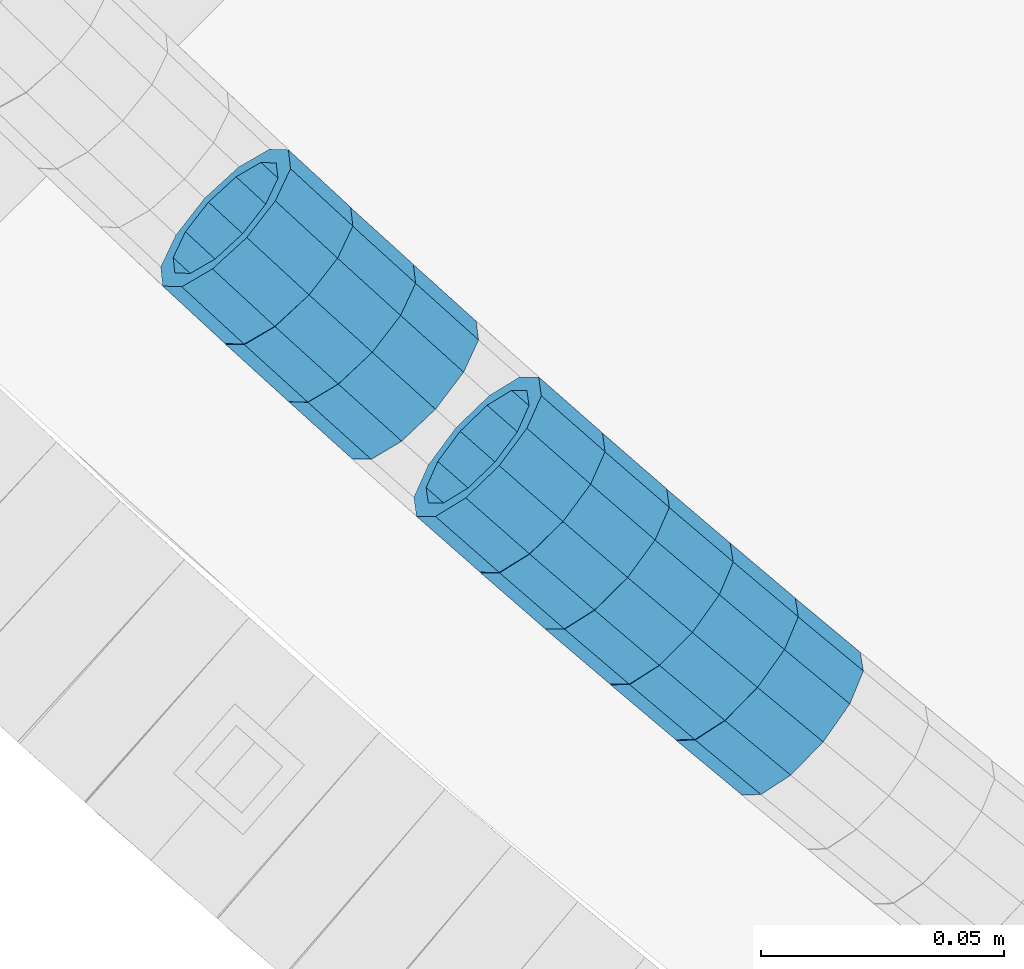
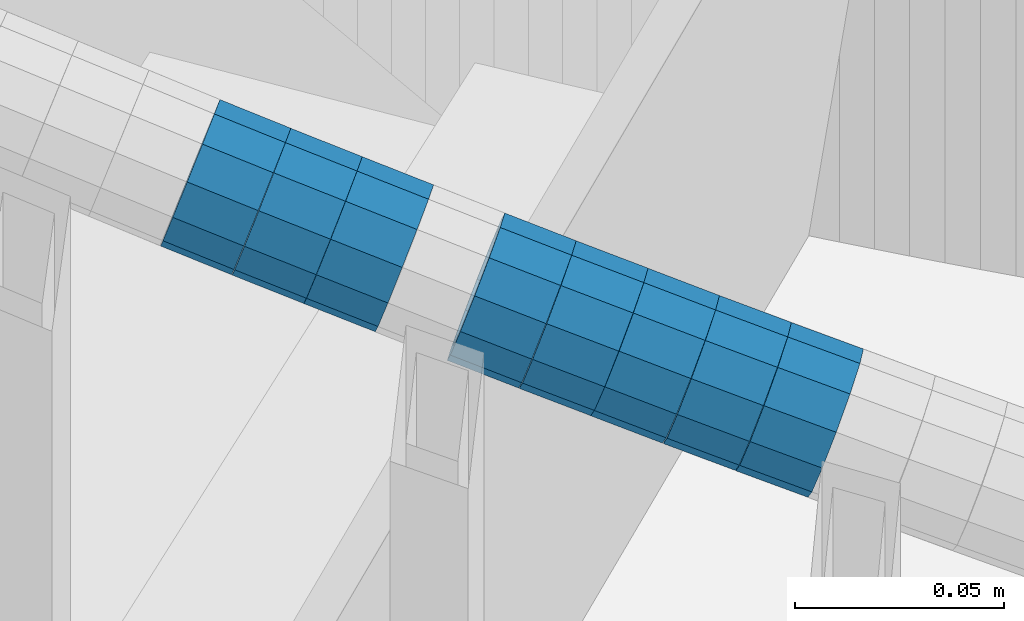
# One storey, part 659 of 975: 8 beams.
"""IFC2X3 building model written with IfcOpenShell, lengths in millimetres."""

from ifc_helpers import new_model, si_unit, frame, origin_with_axes, place, context, subcontext, project, spatial, faceted_brep, material, type_object, element, save


model = new_model("IFC2X3")

# Units and contexts
model_context = context("Model", 3, precision=1e-05, world=origin_with_axes())
body_context = subcontext(model_context, "Body", "Model", "MODEL_VIEW")
ifc_project = project(units=[si_unit("LENGTHUNIT", "METRE", prefix="MILLI"), si_unit("AREAUNIT", "SQUARE_METRE"), si_unit("VOLUMEUNIT", "CUBIC_METRE"), si_unit("MASSUNIT", "GRAM", prefix="KILO"), si_unit("TIMEUNIT", "SECOND"), si_unit("PLANEANGLEUNIT", "RADIAN"), si_unit("SOLIDANGLEUNIT", "STERADIAN"), si_unit("THERMODYNAMICTEMPERATUREUNIT", "DEGREE_CELSIUS"), si_unit("LUMINOUSINTENSITYUNIT", "LUMEN")], contexts=[model_context])

# Site, building, storey
site_placement = place(None, origin_with_axes())
site = spatial("IfcSite", under=ifc_project, at=site_placement, CompositionType="ELEMENT")
building_placement = place(site_placement, origin_with_axes())
building = spatial("IfcBuilding", under=site, at=building_placement, Name="Undefined", CompositionType="ELEMENT")
storey_placement = place(building_placement, origin_with_axes())
storey = spatial("IfcBuildingStorey", under=building, at=storey_placement, Name="Undefined", CompositionType="ELEMENT", Elevation=0.0)

# Beams
ifc_material = material()
beam_type = type_object("IfcBeamType", PredefinedType="NOTDEFINED")
beam_1_placement = place(storey_placement, frame((32885.447140122, 1317.11341799505, 4870.99343661402), z_axis=(0.659722162341103, 0.751509593096442, -6.30179783911445e-11), x_axis=(0.714291660288527, -0.627049931253341, -0.310798661125558)))
element("IfcBeam", 1, at=beam_1_placement, inside=storey, type_object=beam_type, material=ifc_material, Name="WALL", context=body_context, shape_type="Brep", body=[
    faceted_brep([(-2.1246523829177e-07, -15.367000000002, 0.0), (-1.83998054126278e-07, -13.3082123799541, 7.68350000000009), (18.3398473276247, -13.3082123799522, 7.68350000000646), (18.3398473276393, -15.3670000000002, 1.81898940354586e-11), (-1.06232619145885e-07, -7.68349999999919, 13.3082123799559), (18.3398473276029, -7.68349999999373, 13.3082123799395), (-3.63797880709171e-12, 3.63797880709171e-12, 15.3670000000002), (18.3398473275956, 5.45696821063757e-12, 15.3669999999802), (1.06225343188271e-07, 7.68350000000646, 13.3082123799559), (18.3398473275993, 7.683500000001, 13.3082123799359), (1.8399441614747e-07, 13.308212379965, 7.68350000000009), (18.3398473276029, 13.3082123799559, 7.68349999998827), (2.12461600312963e-07, 15.3670000000093, 0.0), (18.3398473276247, 15.3669999999966, 7.27595761418343e-12), (1.8399441614747e-07, 13.308212379965, -7.68350000000009), (18.3398473276466, 13.308212379945, -7.68349999997372), (1.06225343188271e-07, 7.68350000000646, -13.3082123799559), (18.3398473276611, 7.68349999999009, -13.3082123799177), (-3.63797880709171e-12, 3.63797880709171e-12, -15.3670000000002), (18.3398473276684, -9.09494701772928e-12, -15.3669999999547), (-1.06232619145885e-07, -7.68349999999919, -13.3082123799559), (18.3398473276684, -7.68350000000828, -13.3082123799104), (-1.83998054126278e-07, -13.3082123799541, -7.68350000000009), (18.3398473276611, -13.3082123799613, -7.68349999996644), (-2.63386027654633e-07, -19.0500000000029, 0.0), (-2.28097633225843e-07, -16.4977839420972, -9.52499999999964), (18.3398473276648, -16.497783942099, -9.52499999996144), (18.3398473276466, -19.0500000000011, 2.18278728425503e-11), (-1.31691194837913e-07, -9.52500000000146, -16.4977839420935), (18.3398473276793, -9.52500000000873, -16.4977839420426), (-3.63797880709171e-12, 3.63797880709171e-12, -19.0500000000002), (18.3398473276793, -1.09139364212751e-11, -19.0499999999483), (1.31687556859106e-07, 9.52500000000509, -16.4977839420935), (18.339847327672, 9.52499999998872, -16.4977839420462), (2.28097633225843e-07, 16.4977839421044, -9.52499999999964), (18.3398473276466, 16.4977839420844, -9.52499999997235), (2.63382389675826e-07, 19.0500000000138, 0.0), (18.3398473276247, 19.0499999999938, 7.27595761418343e-12), (2.28097633225843e-07, 16.4977839421044, 9.52499999999964), (18.3398473275993, 16.4977839420935, 9.5249999999869), (1.31687556859106e-07, 9.52500000000509, 16.4977839420935), (18.3398473275884, 9.52500000000327, 16.4977839420681), (-3.63797880709171e-12, 3.63797880709171e-12, 19.0500000000002), (18.3398473275884, 7.27595761418343e-12, 19.0499999999738), (-1.31691194837913e-07, -9.52500000000146, 16.4977839420935), (18.3398473276029, -9.52499999999236, 16.4977839420753), (-2.28097633225843e-07, -16.4977839420972, 9.52499999999964), (18.3398473276211, -16.4977839420899, 9.52499999999782)], [[[0, 1, 2, 3]], [[1, 4, 5, 2]], [[4, 6, 7, 5]], [[6, 8, 9, 7]], [[8, 10, 11, 9]], [[10, 12, 13, 11]], [[12, 14, 15, 13]], [[14, 16, 17, 15]], [[16, 18, 19, 17]], [[18, 20, 21, 19]], [[20, 22, 23, 21]], [[22, 0, 3, 23]], [[24, 25, 26, 27]], [[25, 28, 29, 26]], [[28, 30, 31, 29]], [[30, 32, 33, 31]], [[32, 34, 35, 33]], [[34, 36, 37, 35]], [[36, 38, 39, 37]], [[38, 40, 41, 39]], [[40, 42, 43, 41]], [[42, 44, 45, 43]], [[44, 46, 47, 45]], [[46, 24, 27, 47]], [[29, 31, 33, 35, 37, 39, 41, 43, 45, 47, 27, 26], [5, 7, 9, 11, 13, 15, 17, 19, 21, 23, 3, 2]], [[46, 44, 42, 40, 38, 36, 34, 32, 30, 28, 25, 24], [22, 20, 18, 16, 14, 12, 10, 8, 6, 4, 1, 0]]]),
])
beam_2_placement = place(storey_placement, frame((32846.4408582709, 1352.26107727373, 4888.18099728971), z_axis=(0.672105592443994, 0.740455314388051, 2.18336936086416e-10), x_axis=(0.704268340887311, -0.639258954897755, -0.308794579950596)))
element("IfcBeam", 2, at=beam_2_placement, inside=storey, type_object=beam_type, material=ifc_material, Name="WALL", context=body_context, shape_type="Brep", body=[
    faceted_brep([(-2.1246523829177e-07, -15.367000000002, 0.0), (-1.83998054126278e-07, -13.3082123799541, 7.68350000000009), (18.4599566630168, -13.3082123799522, 7.68349999999555), (18.4599566630277, -15.3670000000002, 3.63797880709171e-12), (-1.06232619145885e-07, -7.68349999999919, 13.3082123799559), (18.4599566630131, -7.68349999999373, 13.3082123799468), (-3.63797880709171e-12, 3.63797880709171e-12, 15.3670000000002), (18.4599566630059, 7.27595761418343e-12, 15.3669999999911), (1.06225343188271e-07, 7.68350000000646, 13.3082123799559), (18.4599566630059, 7.68350000000646, 13.3082123799431), (1.8399441614747e-07, 13.308212379965, 7.68350000000009), (18.4599566630131, 13.3082123799595, 7.68349999999555), (2.12461600312963e-07, 15.3670000000093, 0.0), (18.4599566630241, 15.3670000000002, 0.0), (1.8399441614747e-07, 13.308212379965, -7.68350000000009), (18.4599566630313, 13.3082123799522, -7.68349999999191), (1.06225343188271e-07, 7.68350000000646, -13.3082123799559), (18.459956663035, 7.68349999999555, -13.3082123799431), (-3.63797880709171e-12, 3.63797880709171e-12, -15.3670000000002), (18.459956663035, -3.63797880709171e-12, -15.3669999999875), (-1.06232619145885e-07, -7.68349999999919, -13.3082123799559), (18.459956663035, -7.68350000000464, -13.3082123799431), (-1.83998054126278e-07, -13.3082123799541, -7.68350000000009), (18.459956663035, -13.3082123799559, -7.68349999999191), (-2.63386027654633e-07, -19.0500000000029, 0.0), (-2.28097633225843e-07, -16.4977839420972, -9.52499999999964), (18.459956663035, -16.4977839420953, -9.5249999999869), (18.4599566630241, -19.0499999999975, 3.63797880709171e-12), (-1.31691194837913e-07, -9.52500000000146, -16.4977839420935), (18.4599566630386, -9.52500000000327, -16.497783942079), (-3.63797880709171e-12, 3.63797880709171e-12, -19.0500000000002), (18.4599566630422, -5.45696821063757e-12, -19.0499999999811), (1.31687556859106e-07, 9.52500000000509, -16.4977839420935), (18.4599566630386, 9.52499999999418, -16.497783942079), (2.28097633225843e-07, 16.4977839421044, -9.52499999999964), (18.4599566630277, 16.4977839420917, -9.52499999999418), (2.63382389675826e-07, 19.0500000000138, 0.0), (18.4599566630168, 19.0500000000011, -3.63797880709171e-12), (2.28097633225843e-07, 16.4977839421044, 9.52499999999964), (18.4599566630131, 16.4977839420972, 9.52499999999054), (1.31687556859106e-07, 9.52500000000509, 16.4977839420935), (18.4599566630095, 9.52500000000691, 16.497783942079), (-3.63797880709171e-12, 3.63797880709171e-12, 19.0500000000002), (18.4599566630059, 7.27595761418343e-12, 19.0499999999884), (-1.31691194837913e-07, -9.52500000000146, 16.4977839420935), (18.4599566630095, -9.52499999999236, 16.4977839420826), (-2.28097633225843e-07, -16.4977839420972, 9.52499999999964), (18.4599566630168, -16.4977839420881, 9.52499999999418)], [[[0, 1, 2, 3]], [[1, 4, 5, 2]], [[4, 6, 7, 5]], [[6, 8, 9, 7]], [[8, 10, 11, 9]], [[10, 12, 13, 11]], [[12, 14, 15, 13]], [[14, 16, 17, 15]], [[16, 18, 19, 17]], [[18, 20, 21, 19]], [[20, 22, 23, 21]], [[22, 0, 3, 23]], [[24, 25, 26, 27]], [[25, 28, 29, 26]], [[28, 30, 31, 29]], [[30, 32, 33, 31]], [[32, 34, 35, 33]], [[34, 36, 37, 35]], [[36, 38, 39, 37]], [[38, 40, 41, 39]], [[40, 42, 43, 41]], [[42, 44, 45, 43]], [[44, 46, 47, 45]], [[46, 24, 27, 47]], [[29, 31, 33, 35, 37, 39, 41, 43, 45, 47, 27, 26], [5, 7, 9, 11, 13, 15, 17, 19, 21, 23, 3, 2]], [[46, 44, 42, 40, 38, 36, 34, 32, 30, 28, 25, 24], [22, 20, 18, 16, 14, 12, 10, 8, 6, 4, 1, 0]]]),
])
beam_3_placement = place(storey_placement, frame((32898.5526975235, 1305.54987548139, 4865.27848180664), z_axis=(0.65406398915987, 0.756439222994338, 2.04823663807474e-10), x_axis=(0.719570981002803, -0.622185434002454, -0.308387563001237)))
element("IfcBeam", 3, at=beam_3_placement, inside=storey, type_object=beam_type, material=ifc_material, Name="WALL", context=body_context, shape_type="Brep", body=[
    faceted_brep([(-2.1246523829177e-07, -15.367000000002, 0.0), (-1.83998054126278e-07, -13.3082123799541, 7.68350000000009), (18.4753890351749, -13.3082123799613, 7.6835000000101), (18.4753890351676, -15.3670000000056, 0.0), (-1.06232619145885e-07, -7.68349999999919, 13.3082123799559), (18.4753890351822, -7.6835000000101, 13.3082123799686), (-3.63797880709171e-12, 3.63797880709171e-12, 15.3670000000002), (18.4753890351967, -1.2732925824821e-11, 15.3670000000238), (1.06225343188271e-07, 7.68350000000646, 13.3082123799559), (18.475389035204, 7.68349999998463, 13.3082123799832), (1.8399441614747e-07, 13.308212379965, 7.68350000000009), (18.4753890352004, 13.3082123799395, 7.68350000002465), (2.12461600312963e-07, 15.3670000000093, 0.0), (18.4753890351967, 15.3669999999838, 2.5465851649642e-11), (1.8399441614747e-07, 13.308212379965, -7.68350000000009), (18.4753890351894, 13.3082123799413, -7.68349999998463), (1.06225343188271e-07, 7.68350000000646, -13.3082123799559), (18.4753890351749, 7.68349999998827, -13.3082123799468), (-3.63797880709171e-12, 3.63797880709171e-12, -15.3670000000002), (18.4753890351676, -1.09139364212751e-11, -15.3669999999947), (-1.06232619145885e-07, -7.68349999999919, -13.3082123799559), (18.4753890351676, -7.68350000000646, -13.3082123799577), (-1.83998054126278e-07, -13.3082123799541, -7.68350000000009), (18.4753890351567, -13.3082123799613, -7.68350000000282), (-2.63386027654633e-07, -19.0500000000029, 0.0), (-2.28097633225843e-07, -16.4977839420972, -9.52499999999964), (18.4753890351567, -16.4977839420972, -9.52500000000873), (18.4753890351676, -19.0500000000065, 0.0), (-1.31691194837913e-07, -9.52500000000146, -16.4977839420935), (18.475389035164, -9.52500000000873, -16.4977839420972), (-3.63797880709171e-12, 3.63797880709171e-12, -19.0500000000002), (18.475389035164, -9.09494701772928e-12, -19.0499999999993), (1.31687556859106e-07, 9.52500000000509, -16.4977839420935), (18.4753890351822, 9.5249999999869, -16.497783942079), (2.28097633225843e-07, 16.4977839421044, -9.52499999999964), (18.4753890351931, 16.497783942079, -9.52499999997963), (2.63382389675826e-07, 19.0500000000138, 0.0), (18.475389035204, 19.0499999999847, 2.91038304567337e-11), (2.28097633225843e-07, 16.4977839421044, 9.52499999999964), (18.4753890352113, 16.4977839420753, 9.5250000000342), (1.31687556859106e-07, 9.52500000000509, 16.4977839420935), (18.475389035204, 9.52499999998327, 16.4977839421226), (-3.63797880709171e-12, 3.63797880709171e-12, 19.0500000000002), (18.4753890352004, -1.45519152283669e-11, 19.0500000000284), (-1.31691194837913e-07, -9.52500000000146, 16.4977839420935), (18.4753890351858, -9.52500000000873, 16.4977839421081), (-2.28097633225843e-07, -16.4977839420972, 9.52499999999964), (18.4753890351749, -16.4977839421008, 9.52500000000509)], [[[0, 1, 2, 3]], [[1, 4, 5, 2]], [[4, 6, 7, 5]], [[6, 8, 9, 7]], [[8, 10, 11, 9]], [[10, 12, 13, 11]], [[12, 14, 15, 13]], [[14, 16, 17, 15]], [[16, 18, 19, 17]], [[18, 20, 21, 19]], [[20, 22, 23, 21]], [[22, 0, 3, 23]], [[24, 25, 26, 27]], [[25, 28, 29, 26]], [[28, 30, 31, 29]], [[30, 32, 33, 31]], [[32, 34, 35, 33]], [[34, 36, 37, 35]], [[36, 38, 39, 37]], [[38, 40, 41, 39]], [[40, 42, 43, 41]], [[42, 44, 45, 43]], [[44, 46, 47, 45]], [[46, 24, 27, 47]], [[29, 31, 33, 35, 37, 39, 41, 43, 45, 47, 27, 26], [5, 7, 9, 11, 13, 15, 17, 19, 21, 23, 3, 2]], [[46, 44, 42, 40, 38, 36, 34, 32, 30, 28, 25, 24], [22, 20, 18, 16, 14, 12, 10, 8, 6, 4, 1, 0]]]),
])
beam_4_placement = place(storey_placement, frame((32911.7181026695, 1294.0974046981, 4859.62218127708), z_axis=(0.647482078321744, 0.762080676996967, 1.71126885106787e-10), x_axis=(0.723189311042996, -0.6144390380365, -0.315375790018729)))
element("IfcBeam", 4, at=beam_4_placement, inside=storey, type_object=beam_type, material=ifc_material, Name="WALL", context=body_context, shape_type="Brep", body=[
    faceted_brep([(-2.1246523829177e-07, -15.367000000002, 0.0), (-1.83998054126278e-07, -13.3082123799541, 7.68350000000009), (18.3929334256754, -13.3082123799595, 7.68350000001374), (18.39293342569, -15.3670000000111, 3.27418092638254e-11), (-1.06232619145885e-07, -7.68349999999919, 13.3082123799559), (18.3929334256572, -7.68349999999373, 13.3082123799504), (-3.63797880709171e-12, 3.63797880709171e-12, 15.3670000000002), (18.3929334256391, 1.2732925824821e-11, 15.3669999999802), (1.06225343188271e-07, 7.68350000000646, 13.3082123799559), (18.3929334256318, 7.68350000001556, 13.3082123799286), (1.8399441614747e-07, 13.308212379965, 7.68350000000009), (18.3929334256391, 13.3082123799704, 7.68349999997736), (2.12461600312963e-07, 15.3670000000093, 0.0), (18.3929334256536, 15.3670000000111, -1.09139364212751e-11), (1.8399441614747e-07, 13.308212379965, -7.68350000000009), (18.3929334256682, 13.3082123799595, -7.68349999999191), (1.06225343188271e-07, 7.68350000000646, -13.3082123799559), (18.3929334256864, 7.68349999999373, -13.3082123799286), (-3.63797880709171e-12, 3.63797880709171e-12, -15.3670000000002), (18.3929334257045, -1.2732925824821e-11, -15.3669999999584), (-1.06232619145885e-07, -7.68349999999919, -13.3082123799559), (18.3929334257118, -7.68350000001919, -13.3082123799068), (-1.83998054126278e-07, -13.3082123799541, -7.68350000000009), (18.3929334257082, -13.3082123799704, -7.68349999995553), (-2.63386027654633e-07, -19.0500000000029, 0.0), (-2.28097633225843e-07, -16.4977839420972, -9.52499999999964), (18.3929334257155, -16.4977839421135, -9.52499999994689), (18.3929334257009, -19.0500000000156, 3.63797880709171e-11), (-1.31691194837913e-07, -9.52500000000146, -16.4977839420935), (18.3929334257191, -9.52500000002146, -16.4977839420353), (-3.63797880709171e-12, 3.63797880709171e-12, -19.0500000000002), (18.3929334257155, -1.81898940354586e-11, -19.0499999999483), (1.31687556859106e-07, 9.52500000000509, -16.4977839420935), (18.3929334256936, 9.52499999999236, -16.4977839420608), (2.28097633225843e-07, 16.4977839421044, -9.52499999999964), (18.3929334256682, 16.4977839420953, -9.52499999999418), (2.63382389675826e-07, 19.0500000000138, 0.0), (18.3929334256391, 19.050000000012, -1.81898940354586e-11), (2.28097633225843e-07, 16.4977839421044, 9.52499999999964), (18.3929334256281, 16.4977839421117, 9.52499999996508), (1.31687556859106e-07, 9.52500000000509, 16.4977839420935), (18.3929334256245, 9.52500000001965, 16.4977839420571), (-3.63797880709171e-12, 3.63797880709171e-12, 19.0500000000002), (18.3929334256318, 1.63709046319127e-11, 19.0499999999738), (-1.31691194837913e-07, -9.52500000000146, 16.4977839420935), (18.39293342565, -9.52499999999236, 16.4977839420826), (-2.28097633225843e-07, -16.4977839420972, 9.52499999999964), (18.3929334256754, -16.497783942099, 9.52500000001601)], [[[0, 1, 2, 3]], [[1, 4, 5, 2]], [[4, 6, 7, 5]], [[6, 8, 9, 7]], [[8, 10, 11, 9]], [[10, 12, 13, 11]], [[12, 14, 15, 13]], [[14, 16, 17, 15]], [[16, 18, 19, 17]], [[18, 20, 21, 19]], [[20, 22, 23, 21]], [[22, 0, 3, 23]], [[24, 25, 26, 27]], [[25, 28, 29, 26]], [[28, 30, 31, 29]], [[30, 32, 33, 31]], [[32, 34, 35, 33]], [[34, 36, 37, 35]], [[36, 38, 39, 37]], [[38, 40, 41, 39]], [[40, 42, 43, 41]], [[42, 44, 45, 43]], [[44, 46, 47, 45]], [[46, 24, 27, 47]], [[29, 31, 33, 35, 37, 39, 41, 43, 45, 47, 27, 26], [5, 7, 9, 11, 13, 15, 17, 19, 21, 23, 3, 2]], [[46, 44, 42, 40, 38, 36, 34, 32, 30, 28, 25, 24], [22, 20, 18, 16, 14, 12, 10, 8, 6, 4, 1, 0]]]),
])
beam_5_placement = place(storey_placement, frame((32833.6383893248, 1364.12512967484, 4893.89568681185), z_axis=(0.677802814997399, 0.735243731004625, 1.65255187312141e-12), x_axis=(0.698744505075172, -0.644155091069281, -0.311159662033464)))
element("IfcBeam", 5, at=beam_5_placement, inside=storey, type_object=beam_type, material=ifc_material, Name="WALL", context=body_context, shape_type="Brep", body=[
    faceted_brep([(-2.1246523829177e-07, -15.367000000002, 0.0), (-1.83998054126278e-07, -13.3082123799541, 7.68350000000009), (18.3232093259357, -13.3082123799704, 7.68350000004648), (18.3232093259248, -15.3670000000111, 3.63797880709171e-11), (-1.06232619145885e-07, -7.68349999999919, 13.3082123799559), (18.3232093259394, -7.68350000001556, 13.308212380005), (-3.63797880709171e-12, 3.63797880709171e-12, 15.3670000000002), (18.3232093259285, -1.2732925824821e-11, 15.367000000042), (1.06225343188271e-07, 7.68350000000646, 13.3082123799559), (18.3232093259139, 7.68349999999555, 13.3082123799868), (1.8399441614747e-07, 13.308212379965, 7.68350000000009), (18.3232093258957, 13.3082123799595, 7.6835000000101), (2.12461600312963e-07, 15.3670000000093, 0.0), (18.3232093258812, 15.3670000000111, -7.27595761418343e-12), (1.8399441614747e-07, 13.308212379965, -7.68350000000009), (18.3232093258666, 13.3082123799704, -7.68350000001737), (1.06225343188271e-07, 7.68350000000646, -13.3082123799559), (18.3232093258666, 7.68350000001556, -13.3082123799722), (-3.63797880709171e-12, 3.63797880709171e-12, -15.3670000000002), (18.3232093258703, 1.2732925824821e-11, -15.3670000000166), (-1.06232619145885e-07, -7.68349999999919, -13.3082123799559), (18.3232093258885, -7.68349999999555, -13.3082123799577), (-1.83998054126278e-07, -13.3082123799541, -7.68350000000009), (18.323209325903, -13.3082123799577, -7.68349999998463), (-2.63386027654633e-07, -19.0500000000029, 0.0), (-2.28097633225843e-07, -16.4977839420972, -9.52499999999964), (18.3232093259066, -16.4977839420972, -9.52499999998327), (18.3232093259285, -19.050000000012, 4.00177668780088e-11), (-1.31691194837913e-07, -9.52500000000146, -16.4977839420935), (18.3232093258812, -9.52499999999236, -16.4977839421008), (-3.63797880709171e-12, 3.63797880709171e-12, -19.0500000000002), (18.3232093258666, 1.63709046319127e-11, -19.0500000000211), (1.31687556859106e-07, 9.52500000000509, -16.4977839420935), (18.3232093258557, 9.52500000002146, -16.4977839421226), (2.28097633225843e-07, 16.4977839421044, -9.52499999999964), (18.3232093258557, 16.4977839421135, -9.52500000002692), (2.63382389675826e-07, 19.0500000000138, 0.0), (18.3232093258703, 19.0500000000138, -1.09139364212751e-11), (2.28097633225843e-07, 16.4977839421044, 9.52499999999964), (18.3232093258921, 16.497783942099, 9.52500000000873), (1.31687556859106e-07, 9.52500000000509, 16.4977839420935), (18.3232093259176, 9.52499999999418, 16.4977839421263), (-3.63797880709171e-12, 3.63797880709171e-12, 19.0500000000002), (18.3232093259357, -1.2732925824821e-11, 19.0500000000466), (-1.31691194837913e-07, -9.52500000000146, 16.4977839420935), (18.3232093259467, -9.52500000001783, 16.4977839421481), (-2.28097633225843e-07, -16.4977839420972, 9.52499999999964), (18.323209325943, -16.4977839421135, 9.52500000005239)], [[[0, 1, 2, 3]], [[1, 4, 5, 2]], [[4, 6, 7, 5]], [[6, 8, 9, 7]], [[8, 10, 11, 9]], [[10, 12, 13, 11]], [[12, 14, 15, 13]], [[14, 16, 17, 15]], [[16, 18, 19, 17]], [[18, 20, 21, 19]], [[20, 22, 23, 21]], [[22, 0, 3, 23]], [[24, 25, 26, 27]], [[25, 28, 29, 26]], [[28, 30, 31, 29]], [[30, 32, 33, 31]], [[32, 34, 35, 33]], [[34, 36, 37, 35]], [[36, 38, 39, 37]], [[38, 40, 41, 39]], [[40, 42, 43, 41]], [[42, 44, 45, 43]], [[44, 46, 47, 45]], [[46, 24, 27, 47]], [[29, 31, 33, 35, 37, 39, 41, 43, 45, 47, 27, 26], [5, 7, 9, 11, 13, 15, 17, 19, 21, 23, 3, 2]], [[46, 44, 42, 40, 38, 36, 34, 32, 30, 28, 25, 24], [22, 20, 18, 16, 14, 12, 10, 8, 6, 4, 1, 0]]]),
])
beam_6_placement = place(storey_placement, frame((32925.0930601532, 1282.70516433297, 4853.78378012077), z_axis=(0.644662633098881, 0.764467193204533, 1.82953954208642e-11), x_axis=(0.726995055682571, -0.613062994732261, -0.309244164864928)))
element("IfcBeam", 6, at=beam_6_placement, inside=storey, type_object=beam_type, material=ifc_material, Name="WALL", context=body_context, shape_type="Brep", body=[
    faceted_brep([(-2.1246523829177e-07, -15.367000000002, 0.0), (-1.83998054126278e-07, -13.3082123799541, 7.68350000000009), (18.428781837134, -13.3082123799413, 7.68349999998827), (18.4287818371195, -15.3669999999802, -2.5465851649642e-11), (-1.06232619145885e-07, -7.68349999999919, 13.3082123799559), (18.4287818371522, -7.68349999999373, 13.3082123799577), (-3.63797880709171e-12, 3.63797880709171e-12, 15.3670000000002), (18.4287818371486, 5.45696821063757e-12, 15.367000000002), (1.06225343188271e-07, 7.68350000000646, 13.3082123799559), (18.4287818371558, 7.68350000000282, 13.3082123799577), (1.8399441614747e-07, 13.308212379965, 7.68350000000009), (18.4287818371413, 13.3082123799595, 7.68349999999191), (2.12461600312963e-07, 15.3670000000093, 0.0), (18.4287818371267, 15.3670000000075, -2.18278728425503e-11), (1.8399441614747e-07, 13.308212379965, -7.68350000000009), (18.4287818371122, 13.3082123799668, -7.68350000003193), (1.06225343188271e-07, 7.68350000000646, -13.3082123799559), (18.4287818370976, 7.68350000001737, -13.3082123800014), (-3.63797880709171e-12, 3.63797880709171e-12, -15.3670000000002), (18.428781837094, 2.00088834390044e-11, -15.3670000000529), (-1.06232619145885e-07, -7.68349999999919, -13.3082123799559), (18.4287818370976, -7.68349999997554, -13.308212380005), (-1.83998054126278e-07, -13.3082123799541, -7.68350000000009), (18.4287818371085, -13.308212379934, -7.6835000000392), (-2.63386027654633e-07, -19.0500000000029, 0.0), (-2.28097633225843e-07, -16.4977839420972, -9.52499999999964), (18.4287818371049, -16.4977839420699, -9.52500000004511), (18.4287818371231, -19.0499999999793, -2.5465851649642e-11), (-1.31691194837913e-07, -9.52500000000146, -16.4977839420935), (18.4287818370904, -9.52499999997599, -16.4977839421445), (-3.63797880709171e-12, 3.63797880709171e-12, -19.0500000000002), (18.4287818370831, 2.36468622460961e-11, -19.0500000000611), (1.31687556859106e-07, 9.52500000000509, -16.4977839420935), (18.4287818370904, 9.52500000001965, -16.4977839421481), (2.28097633225843e-07, 16.4977839421044, -9.52499999999964), (18.4287818371049, 16.4977839421063, -9.52500000004147), (2.63382389675826e-07, 19.0500000000138, 0.0), (18.4287818371304, 19.0500000000047, -2.18278728425503e-11), (2.28097633225843e-07, 16.4977839421044, 9.52499999999964), (18.4287818371486, 16.4977839420953, 9.52499999999782), (1.31687556859106e-07, 9.52500000000509, 16.4977839420935), (18.4287818371558, 9.52500000000146, 16.4977839421044), (-3.63797880709171e-12, 3.63797880709171e-12, 19.0500000000002), (18.4287818371631, 1.81898940354586e-12, 19.0500000000138), (-1.31691194837913e-07, -9.52500000000146, 16.4977839420935), (18.4287818371595, -9.52499999999236, 16.4977839421044), (-2.28097633225843e-07, -16.4977839420972, 9.52499999999964), (18.4287818371449, -16.4977839420808, 9.52499999999418)], [[[0, 1, 2, 3]], [[1, 4, 5, 2]], [[4, 6, 7, 5]], [[6, 8, 9, 7]], [[8, 10, 11, 9]], [[10, 12, 13, 11]], [[12, 14, 15, 13]], [[14, 16, 17, 15]], [[16, 18, 19, 17]], [[18, 20, 21, 19]], [[20, 22, 23, 21]], [[22, 0, 3, 23]], [[24, 25, 26, 27]], [[25, 28, 29, 26]], [[28, 30, 31, 29]], [[30, 32, 33, 31]], [[32, 34, 35, 33]], [[34, 36, 37, 35]], [[36, 38, 39, 37]], [[38, 40, 41, 39]], [[40, 42, 43, 41]], [[42, 44, 45, 43]], [[44, 46, 47, 45]], [[46, 24, 27, 47]], [[29, 31, 33, 35, 37, 39, 41, 43, 45, 47, 27, 26], [5, 7, 9, 11, 13, 15, 17, 19, 21, 23, 3, 2]], [[46, 44, 42, 40, 38, 36, 34, 32, 30, 28, 25, 24], [22, 20, 18, 16, 14, 12, 10, 8, 6, 4, 1, 0]]]),
])
beam_7_placement = place(storey_placement, frame((32859.4090019731, 1340.45624212958, 4882.48763025439), z_axis=(0.668964731654239, 0.743294146218556, 1.31408341985661e-10), x_axis=(0.706709629886603, -0.636038666897866, -0.309864991950247)))
element("IfcBeam", 7, at=beam_7_placement, inside=storey, type_object=beam_type, material=ifc_material, Name="WALL", context=body_context, shape_type="Brep", body=[
    faceted_brep([(-2.1246523829177e-07, -15.367000000002, 0.0), (-1.83998054126278e-07, -13.3082123799541, 7.68350000000009), (18.4002717371586, -13.3082123799486, 7.6835000000101), (18.4002717371732, -15.3670000000002, 2.5465851649642e-11), (-1.06232619145885e-07, -7.68349999999919, 13.3082123799559), (18.4002717371368, -7.68349999998645, 13.3082123799431), (-3.63797880709171e-12, 3.63797880709171e-12, 15.3670000000002), (18.400271737115, 2.00088834390044e-11, 15.3669999999656), (1.06225343188271e-07, 7.68350000000646, 13.3082123799559), (18.4002717371004, 7.68350000002283, 13.3082123799068), (1.8399441614747e-07, 13.308212379965, 7.68350000000009), (18.4002717370895, 13.3082123799741, 7.68349999994462), (2.12461600312963e-07, 15.3670000000093, 0.0), (18.4002717370931, 15.3670000000147, -5.45696821063757e-11), (1.8399441614747e-07, 13.308212379965, -7.68350000000009), (18.4002717371004, 13.3082123799632, -7.6835000000392), (1.06225343188271e-07, 7.68350000000646, -13.3082123799559), (18.4002717371259, 7.68349999999919, -13.3082123799759), (-3.63797880709171e-12, 3.63797880709171e-12, -15.3670000000002), (18.4002717371513, -5.45696821063757e-12, -15.3669999999984), (-1.06232619145885e-07, -7.68349999999919, -13.3082123799559), (18.4002717371659, -7.68350000000646, -13.3082123799395), (-1.83998054126278e-07, -13.3082123799541, -7.68350000000009), (18.4002717371732, -13.3082123799613, -7.68349999997736), (-2.63386027654633e-07, -19.0500000000029, 0.0), (-2.28097633225843e-07, -16.4977839420972, -9.52499999999964), (18.4002717371877, -16.4977839421026, -9.52499999996508), (18.4002717371841, -19.0500000000029, 3.63797880709171e-11), (-1.31691194837913e-07, -9.52500000000146, -16.4977839420935), (18.4002717371768, -9.52500000001055, -16.4977839420681), (-3.63797880709171e-12, 3.63797880709171e-12, -19.0500000000002), (18.400271737155, -9.09494701772928e-12, -19.0499999999956), (1.31687556859106e-07, 9.52500000000509, -16.4977839420935), (18.4002717371295, 9.52499999999782, -16.4977839421153), (2.28097633225843e-07, 16.4977839421044, -9.52499999999964), (18.4002717370968, 16.4977839421026, -9.52500000005239), (2.63382389675826e-07, 19.0500000000138, 0.0), (18.4002717370822, 19.0500000000156, -6.54836185276508e-11), (2.28097633225843e-07, 16.4977839421044, 9.52499999999964), (18.4002717370786, 16.4977839421172, 9.52499999993233), (1.31687556859106e-07, 9.52500000000509, 16.4977839420935), (18.4002717370859, 9.5250000000251, 16.497783942039), (-3.63797880709171e-12, 3.63797880709171e-12, 19.0500000000002), (18.4002717371113, 2.36468622460961e-11, 19.0499999999629), (-1.31691194837913e-07, -9.52500000000146, 16.4977839420935), (18.4002717371368, -9.52499999998327, 16.4977839420826), (-2.28097633225843e-07, -16.4977839420972, 9.52499999999964), (18.4002717371623, -16.4977839420844, 9.52500000001601)], [[[0, 1, 2, 3]], [[1, 4, 5, 2]], [[4, 6, 7, 5]], [[6, 8, 9, 7]], [[8, 10, 11, 9]], [[10, 12, 13, 11]], [[12, 14, 15, 13]], [[14, 16, 17, 15]], [[16, 18, 19, 17]], [[18, 20, 21, 19]], [[20, 22, 23, 21]], [[22, 0, 3, 23]], [[24, 25, 26, 27]], [[25, 28, 29, 26]], [[28, 30, 31, 29]], [[30, 32, 33, 31]], [[32, 34, 35, 33]], [[34, 36, 37, 35]], [[36, 38, 39, 37]], [[38, 40, 41, 39]], [[40, 42, 43, 41]], [[42, 44, 45, 43]], [[44, 46, 47, 45]], [[46, 24, 27, 47]], [[29, 31, 33, 35, 37, 39, 41, 43, 45, 47, 27, 26], [5, 7, 9, 11, 13, 15, 17, 19, 21, 23, 3, 2]], [[46, 44, 42, 40, 38, 36, 34, 32, 30, 28, 25, 24], [22, 20, 18, 16, 14, 12, 10, 8, 6, 4, 1, 0]]]),
])
beam_8_placement = place(storey_placement, frame((32938.4656299068, 1271.36642996977, 4848.08254125438), z_axis=(0.638500632539079, 0.769621297942823, -1.46680577017833e-10), x_axis=(0.73194657018858, -0.607244562156425, -0.309044107079598)))
element("IfcBeam", 8, at=beam_8_placement, inside=storey, type_object=beam_type, material=ifc_material, Name="WALL", context=body_context, shape_type="Brep", body=[
    faceted_brep([(-2.1246523829177e-07, -15.367000000002, 0.0), (-1.83998054126278e-07, -13.3082123799541, 7.68350000000009), (18.4442402933746, -13.3082123799431, 7.68349999998463), (18.4442402933928, -15.3669999999893, -3.63797880709171e-12), (-1.06232619145885e-07, -7.68349999999919, 13.3082123799559), (18.4442402933564, -7.68349999998281, 13.308212379925), (-3.63797880709171e-12, 3.63797880709171e-12, 15.3670000000002), (18.4442402933455, 1.81898940354586e-11, 15.3669999999584), (1.06225343188271e-07, 7.68350000000646, 13.3082123799559), (18.4442402933419, 7.68350000001737, 13.3082123799104), (1.8399441614747e-07, 13.308212379965, 7.68350000000009), (18.4442402933528, 13.3082123799722, 7.68349999996281), (2.12461600312963e-07, 15.3670000000093, 0.0), (18.4442402933637, 15.3670000000129, -2.5465851649642e-11), (1.8399441614747e-07, 13.308212379965, -7.68350000000009), (18.4442402933855, 13.308212379965, -7.6835000000101), (1.06225343188271e-07, 7.68350000000646, -13.3082123799559), (18.4442402934037, 7.68350000000646, -13.3082123799541), (-3.63797880709171e-12, 3.63797880709171e-12, -15.3670000000002), (18.444240293411, 5.45696821063757e-12, -15.3669999999911), (-1.06232619145885e-07, -7.68349999999919, -13.3082123799559), (18.4442402934146, -7.68349999999373, -13.3082123799431), (-1.83998054126278e-07, -13.3082123799541, -7.68350000000009), (18.4442402934037, -13.3082123799468, -7.68349999999191), (-2.63386027654633e-07, -19.0500000000029, 0.0), (-2.28097633225843e-07, -16.4977839420972, -9.52499999999964), (18.444240293411, -16.4977839420862, -9.5249999999869), (18.4442402933964, -19.0499999999902, 0.0), (-1.31691194837913e-07, -9.52500000000146, -16.4977839420935), (18.4442402934219, -9.524999999996, -16.4977839420717), (-3.63797880709171e-12, 3.63797880709171e-12, -19.0500000000002), (18.4442402934183, 3.63797880709171e-12, -19.0499999999847), (1.31687556859106e-07, 9.52500000000509, -16.4977839420935), (18.4442402934073, 9.52500000000509, -16.4977839420899), (2.28097633225843e-07, 16.4977839421044, -9.52499999999964), (18.4442402933855, 16.4977839421008, -9.52500000001601), (2.63382389675826e-07, 19.0500000000138, 0.0), (18.4442402933637, 19.0500000000138, -2.91038304567337e-11), (2.28097633225843e-07, 16.4977839421044, 9.52499999999964), (18.4442402933419, 16.4977839421117, 9.52499999995052), (1.31687556859106e-07, 9.52500000000509, 16.4977839420935), (18.4442402933346, 9.52500000001965, 16.4977839420426), (-3.63797880709171e-12, 3.63797880709171e-12, 19.0500000000002), (18.4442402933346, 2.00088834390044e-11, 19.0499999999483), (-1.31691194837913e-07, -9.52500000000146, 16.4977839420935), (18.4442402933528, -9.52499999998145, 16.4977839420571), (-2.28097633225843e-07, -16.4977839420972, 9.52499999999964), (18.4442402933746, -16.497783942079, 9.52499999998327)], [[[0, 1, 2, 3]], [[1, 4, 5, 2]], [[4, 6, 7, 5]], [[6, 8, 9, 7]], [[8, 10, 11, 9]], [[10, 12, 13, 11]], [[12, 14, 15, 13]], [[14, 16, 17, 15]], [[16, 18, 19, 17]], [[18, 20, 21, 19]], [[20, 22, 23, 21]], [[22, 0, 3, 23]], [[24, 25, 26, 27]], [[25, 28, 29, 26]], [[28, 30, 31, 29]], [[30, 32, 33, 31]], [[32, 34, 35, 33]], [[34, 36, 37, 35]], [[36, 38, 39, 37]], [[38, 40, 41, 39]], [[40, 42, 43, 41]], [[42, 44, 45, 43]], [[44, 46, 47, 45]], [[46, 24, 27, 47]], [[29, 31, 33, 35, 37, 39, 41, 43, 45, 47, 27, 26], [5, 7, 9, 11, 13, 15, 17, 19, 21, 23, 3, 2]], [[46, 44, 42, 40, 38, 36, 34, 32, 30, 28, 25, 24], [22, 20, 18, 16, 14, 12, 10, 8, 6, 4, 1, 0]]]),
])

save(model, "model.ifc")
